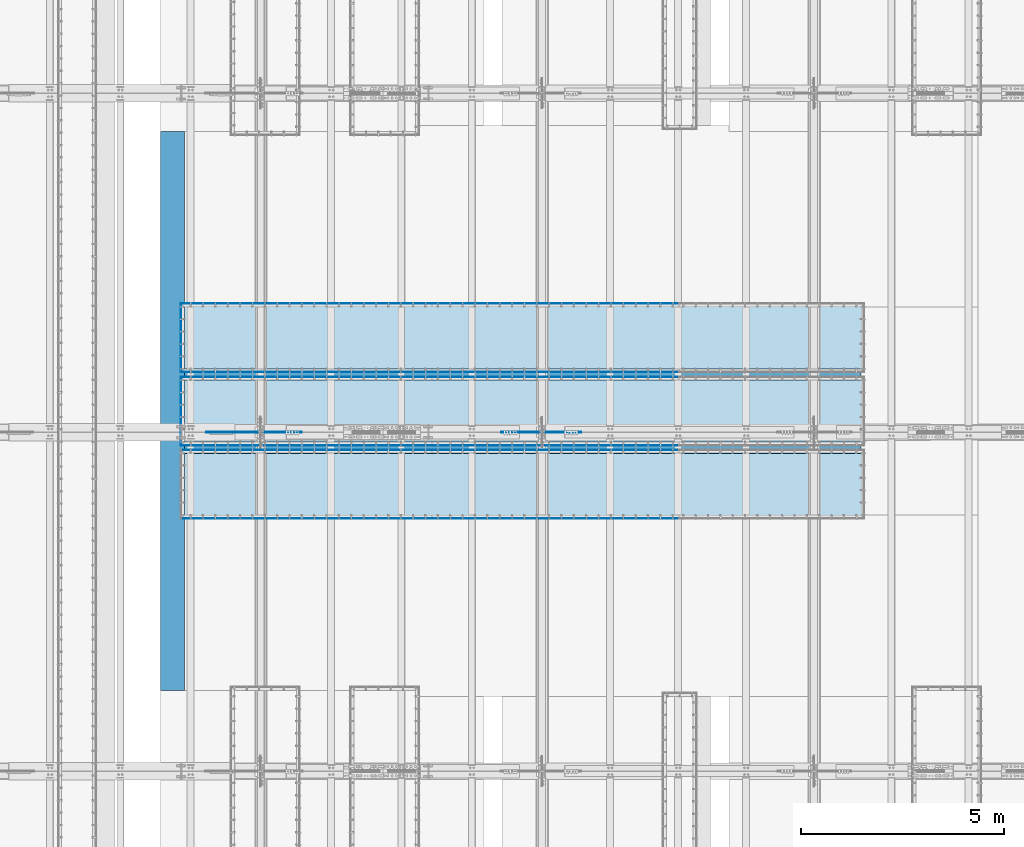
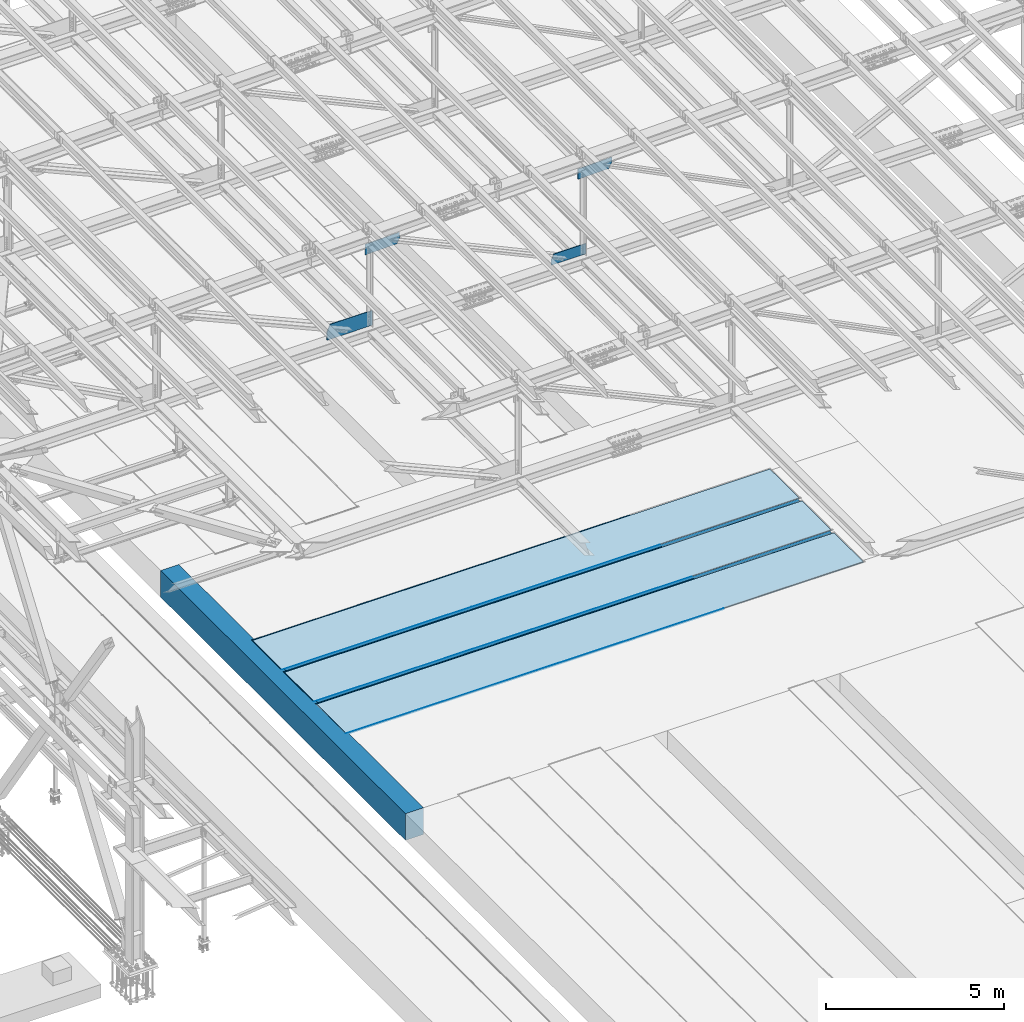
# One storey, part 2982 of 3843: 21 plates, 3 slabs, 24 elements without a shape of their own.
"""IFC2X3 building model written with IfcOpenShell, lengths in millimetres."""

from ifc_helpers import new_model, si_unit, frame, origin_with_axes, place, context, subcontext, project, spatial, faceted_brep, material, type_object, element, aggregate, save


model = new_model("IFC2X3")

# Units and contexts
model_context = context("Model", 3, precision=1e-05, world=origin_with_axes())
body_context = subcontext(model_context, "Body", "Model", "MODEL_VIEW")
ifc_project = project(units=[si_unit("LENGTHUNIT", "METRE", prefix="MILLI"), si_unit("AREAUNIT", "SQUARE_METRE"), si_unit("VOLUMEUNIT", "CUBIC_METRE"), si_unit("MASSUNIT", "GRAM", prefix="KILO"), si_unit("TIMEUNIT", "SECOND"), si_unit("PLANEANGLEUNIT", "RADIAN"), si_unit("SOLIDANGLEUNIT", "STERADIAN"), si_unit("THERMODYNAMICTEMPERATUREUNIT", "DEGREE_CELSIUS"), si_unit("LUMINOUSINTENSITYUNIT", "LUMEN")], contexts=[model_context])

# Site, building, storey
site_placement = place(None, origin_with_axes())
site = spatial("IfcSite", under=ifc_project, at=site_placement, CompositionType="ELEMENT")
building_placement = place(site_placement, origin_with_axes())
building = spatial("IfcBuilding", under=site, at=building_placement, Name="Undefined", CompositionType="ELEMENT")
storey_placement = place(building_placement, origin_with_axes())
storey = spatial("IfcBuildingStorey", under=building, at=storey_placement, Name="Undefined", CompositionType="ELEMENT", Elevation=0.0)

# Assembly, plate
assembly_1_placement = place(storey_placement, origin_with_axes())
assembly_1 = element("IfcElementAssembly", 1, at=assembly_1_placement, inside=storey, Name="EMBED_ANGLE", AssemblyPlace="NOTDEFINED", PredefinedType="RIGID_FRAME")
ifc_material_1 = material(Name="STEEL/A36")
plate_type_1 = type_object("IfcPlateType", PredefinedType="NOTDEFINED")
plate_1_placement = place(assembly_1_placement, frame((47028.862390625, 60391.294, 30480.0000003815), z_axis=(0.0, 1.0, 0.0), x_axis=(0.0, 0.0, -1.0)))
plate_1 = element("IfcPlate", 2, at=plate_1_placement, type_object=plate_type_1, material=ifc_material_1, Name="PLATE", context=body_context, shape_type="Brep", body=[
    faceted_brep([(7.27595761418343e-12, 6.3499999046162, 0.0), (20.6374996185295, 6.35000000000218, -7.27595761418343e-12), (25.399999618523, 1.58750000001601, 4.76249999998981), (25.3999996185303, -6.34999999999854, 12.7000000000044), (0.0, -6.34999999999854, 12.6999998092651), (25.3999996154307, 1.58750000001601, 1697.41850000675), (25.3999996185303, -6.34999999999854, 1689.48100001796), (3.78626282326877e-07, -6.34999999999854, 1689.48100001796), (3.81471181754023e-07, 6.34999999999854, 1702.181), (20.6374996154154, 6.34999999999854, 1702.18100000139)], [[[0, 1, 2, 3, 4]], [[3, 2, 5, 6]], [[4, 3, 6, 7]], [[0, 4, 7, 8]], [[1, 0, 8, 9]], [[2, 1, 9, 5]], [[8, 7, 6, 5, 9]]]),
])
aggregate(assembly_1, [plate_1])

assembly_2_placement = place(storey_placement, origin_with_axes())
assembly_2 = element("IfcElementAssembly", 3, at=assembly_2_placement, inside=storey, Name="EMBED_ANGLE", AssemblyPlace="NOTDEFINED", PredefinedType="RIGID_FRAME")
plate_2_placement = place(assembly_2_placement, frame((53207.4119781899, 60397.6439999965, 30480.0000025529), z_axis=(0.999999999868683, 0.0, 1.62059999202029e-05), x_axis=(1.62059999200984e-05, 0.0, -0.999999999868683)))
plate_2 = element("IfcPlate", 4, at=plate_2_placement, type_object=plate_type_1, material=ifc_material_1, Name="PLATE", context=body_context, shape_type="Brep", body=[
    faceted_brep([(25.4987902105895, -1.5874999999869, 6096.00000000218), (20.736291417099, -6.34999999999854, 6096.00009155487), (20.6375000381231, -6.35000000004948, 2.5465851649642e-11), (25.3999996185921, -1.5874999999869, 7.27595761418343e-11), (0.0, -6.3499999046162, 0.0), (0.0987892300327076, -6.34999999999854, 6096.00048828339), (0.0987892300327076, 6.34999999999854, 6096.00048828339), (7.27595761418343e-12, 6.3499999046162, 0.0), (25.4987888411197, 6.34999999999854, 6096.0000000022), (25.3999999999942, 6.34999999994034, 2.91038304567337e-11)], [[[0, 1, 2, 3]], [[4, 5, 6, 7]], [[8, 9, 7, 6]], [[9, 8, 0, 3]], [[4, 7, 9, 3, 2]], [[5, 4, 2, 1]], [[8, 6, 5, 1, 0]]]),
])
aggregate(assembly_2, [plate_2])

assembly_3_placement = place(storey_placement, origin_with_axes())
assembly_3 = element("IfcElementAssembly", 5, at=assembly_3_placement, inside=storey, Name="EMBED_ANGLE", AssemblyPlace="NOTDEFINED", PredefinedType="RIGID_FRAME")
plate_3_placement = place(assembly_3_placement, frame((47022.512390625, 60397.6439999965, 30480.0000025529), z_axis=(0.999999999868683, 0.0, 1.62059999202029e-05), x_axis=(1.62059999200984e-05, 0.0, -0.999999999868683)))
plate_3 = element("IfcPlate", 6, at=plate_3_placement, type_object=plate_type_1, material=ifc_material_1, Name="PLATE", context=body_context, shape_type="Brep", body=[
    faceted_brep([(25.5002296598104, 6.34999999999854, 6184.89958756838), (0.100230048672529, 6.34999999999854, 6184.90007584957), (0.100230048672529, -6.34999999999854, 6184.90007584957), (20.7377321294189, -6.34999999999854, 6184.89967912107), (25.5002309229349, -1.58749999997235, 6184.89958756837), (25.4002054231096, 6.34999999999854, 12.6995883069176), (0.000205811182240723, 6.34999999999854, 12.6999999392137), (0.0, -6.3499999046162, 0.0), (20.6375000381231, -6.35000000004948, 2.5465851649642e-11), (25.4000767920879, -1.58749999997235, 4.76208830797987)], [[[0, 1, 2, 3, 4]], [[1, 0, 5, 6]], [[2, 1, 6, 7]], [[3, 2, 7, 8]], [[4, 3, 8, 9]], [[0, 4, 9, 5]], [[8, 7, 6, 5, 9]]]),
])
aggregate(assembly_3, [plate_3])

assembly_4_placement = place(storey_placement, origin_with_axes())
assembly_4 = element("IfcElementAssembly", 7, at=assembly_4_placement, inside=storey, Name="EMBED_ANGLE", AssemblyPlace="NOTDEFINED", PredefinedType="RIGID_FRAME")
plate_4_placement = place(assembly_4_placement, frame((53207.4119781899, 62087.1249999965, 30480.0000025529), z_axis=(0.999999999868683, 0.0, 1.62059999202029e-05), x_axis=(1.62059999200984e-05, 0.0, -0.999999999868683)))
plate_4 = element("IfcPlate", 8, at=plate_4_placement, type_object=plate_type_1, material=ifc_material_1, Name="PLATE", context=body_context, shape_type="Brep", body=[
    faceted_brep([(25.4987943539782, 1.58750000000146, 6096.00000000211), (25.3999996185921, 1.58750000000146, 7.27595761418343e-11), (20.6374996185295, 6.35000000000218, -7.27595761418343e-12), (20.7362914171135, 6.34999999999854, 6096.00009155487), (0.0, -6.3499999046162, 0.0), (0.0987892300327076, -6.34999999999854, 6096.00048828339), (0.0987892300327076, 6.34999999999854, 6096.00048828339), (7.27595761418343e-12, 6.3499999046162, 0.0), (25.3999996185303, -6.34999999999491, 2.91038304567337e-11), (25.4987888411197, -6.34999999999854, 6096.0000000022)], [[[0, 1, 2, 3]], [[4, 5, 6, 7]], [[8, 9, 5, 4]], [[6, 5, 9, 0, 3]], [[7, 6, 3, 2]], [[8, 4, 7, 2, 1]], [[9, 8, 1, 0]]]),
])
aggregate(assembly_4, [plate_4])

assembly_5_placement = place(storey_placement, origin_with_axes())
assembly_5 = element("IfcElementAssembly", 9, at=assembly_5_placement, inside=storey, Name="EMBED_ANGLE", AssemblyPlace="NOTDEFINED", PredefinedType="RIGID_FRAME")
plate_5_placement = place(assembly_5_placement, frame((47022.5119781899, 62087.1249999965, 30480.0000025529), z_axis=(0.999999999868683, 0.0, 1.62059999202029e-05), x_axis=(1.62059999200984e-05, 0.0, -0.999999999868683)))
plate_5 = element("IfcPlate", 10, at=plate_5_placement, type_object=plate_type_1, material=ifc_material_1, Name="PLATE", context=body_context, shape_type="Brep", body=[
    faceted_brep([(0.100230055359134, 6.34999999999854, 6184.90048828463), (0.100230055359134, -6.34999999999854, 6184.90048828463), (25.500229666497, -6.34999999999854, 6184.90000000344), (25.5002350729919, 1.58750000003056, 6184.90000000335), (20.7377321361273, 6.34999999999854, 6184.90009155612), (25.4002054297998, -6.34999999999854, 12.7000008638424), (25.4000768019687, 1.58750000003056, 4.76250086484652), (20.6374996185295, 6.35000000000218, -7.27595761418343e-12), (7.27595761418343e-12, 6.3499999046162, 0.0), (0.000205817865207791, -6.34999999999854, 12.7004124961386)], [[[0, 1, 2, 3, 4]], [[3, 2, 5, 6]], [[4, 3, 6, 7]], [[0, 4, 7, 8]], [[1, 0, 8, 9]], [[2, 1, 9, 5]], [[8, 7, 6, 5, 9]]]),
])
aggregate(assembly_5, [plate_5])

assembly_6_placement = place(storey_placement, origin_with_axes())
assembly_6 = element("IfcElementAssembly", 11, at=assembly_6_placement, inside=storey, Name="EMBED_ANGLE", AssemblyPlace="NOTDEFINED", PredefinedType="RIGID_FRAME")
plate_6_placement = place(assembly_6_placement, frame((47028.862390625, 58587.894, 30480.0000003815), z_axis=(0.0, 1.0, 0.0), x_axis=(0.0, 0.0, -1.0)))
plate_6 = element("IfcPlate", 12, at=plate_6_placement, type_object=plate_type_1, material=ifc_material_1, Name="PLATE", context=body_context, shape_type="Brep", body=[
    faceted_brep([(7.27595761418343e-12, 6.3499999046162, 0.0), (20.6374996185295, 6.35000000000218, -7.27595761418343e-12), (25.399999618523, 1.58750000001601, 4.76249999998981), (25.3999996185303, -6.34999999999854, 12.7000000000044), (0.0, -6.34999999999854, 12.6999998092651), (25.3999996154307, 1.58750000001601, 1697.41850000675), (25.3999996185303, -6.34999999999854, 1689.48100001796), (3.78626282326877e-07, -6.34999999999854, 1689.48100001796), (3.81471181754023e-07, 6.34999999999854, 1702.181), (20.6374996154154, 6.34999999999854, 1702.18100000139)], [[[0, 1, 2, 3, 4]], [[3, 2, 5, 6]], [[4, 3, 6, 7]], [[0, 4, 7, 8]], [[1, 0, 8, 9]], [[2, 1, 9, 5]], [[8, 7, 6, 5, 9]]]),
])
aggregate(assembly_6, [plate_6])

assembly_7_placement = place(storey_placement, origin_with_axes())
assembly_7 = element("IfcElementAssembly", 13, at=assembly_7_placement, inside=storey, Name="EMBED_ANGLE", AssemblyPlace="NOTDEFINED", PredefinedType="RIGID_FRAME")
plate_7_placement = place(assembly_7_placement, frame((53207.4119781899, 58594.2439999965, 30480.0000025529), z_axis=(0.999999999868683, 0.0, 1.62059999202029e-05), x_axis=(1.62059999200984e-05, 0.0, -0.999999999868683)))
plate_7 = element("IfcPlate", 14, at=plate_7_placement, type_object=plate_type_1, material=ifc_material_1, Name="PLATE", context=body_context, shape_type="Brep", body=[
    faceted_brep([(25.4987902105895, -1.5874999999869, 6096.00000000218), (20.736291417099, -6.34999999999854, 6096.00009155487), (20.6375000381231, -6.35000000004948, 2.5465851649642e-11), (25.3999996185921, -1.5874999999869, 7.27595761418343e-11), (0.0, -6.3499999046162, 0.0), (0.0987892300327076, -6.34999999999854, 6096.00048828339), (0.0987892300327076, 6.34999999999854, 6096.00048828339), (7.27595761418343e-12, 6.3499999046162, 0.0), (25.4987888411197, 6.34999999999854, 6096.0000000022), (25.3999999999942, 6.34999999994034, 2.91038304567337e-11)], [[[0, 1, 2, 3]], [[4, 5, 6, 7]], [[8, 9, 7, 6]], [[9, 8, 0, 3]], [[4, 7, 9, 3, 2]], [[5, 4, 2, 1]], [[8, 6, 5, 1, 0]]]),
])
aggregate(assembly_7, [plate_7])

assembly_8_placement = place(storey_placement, origin_with_axes())
assembly_8 = element("IfcElementAssembly", 15, at=assembly_8_placement, inside=storey, Name="EMBED_ANGLE", AssemblyPlace="NOTDEFINED", PredefinedType="RIGID_FRAME")
plate_8_placement = place(assembly_8_placement, frame((47022.512390625, 58594.2439999965, 30480.0000025529), z_axis=(0.999999999868683, 0.0, 1.62059999202029e-05), x_axis=(1.62059999200984e-05, 0.0, -0.999999999868683)))
plate_8 = element("IfcPlate", 16, at=plate_8_placement, type_object=plate_type_1, material=ifc_material_1, Name="PLATE", context=body_context, shape_type="Brep", body=[
    faceted_brep([(25.5002296598104, 6.34999999999854, 6184.89958756838), (0.100230048672529, 6.34999999999854, 6184.90007584957), (0.100230048672529, -6.34999999999854, 6184.90007584957), (20.7377321294189, -6.34999999999854, 6184.89967912107), (25.5002309229349, -1.58749999997235, 6184.89958756837), (25.4002054231096, 6.34999999999854, 12.6995883069176), (0.000205811182240723, 6.34999999999854, 12.6999999392137), (0.0, -6.3499999046162, 0.0), (20.6375000381231, -6.35000000004948, 2.5465851649642e-11), (25.4000767920879, -1.58749999997235, 4.76208830797987)], [[[0, 1, 2, 3, 4]], [[1, 0, 5, 6]], [[2, 1, 6, 7]], [[3, 2, 7, 8]], [[4, 3, 8, 9]], [[0, 4, 9, 5]], [[8, 7, 6, 5, 9]]]),
])
aggregate(assembly_8, [plate_8])

assembly_9_placement = place(storey_placement, origin_with_axes())
assembly_9 = element("IfcElementAssembly", 17, at=assembly_9_placement, inside=storey, Name="EMBED_ANGLE", AssemblyPlace="NOTDEFINED", PredefinedType="RIGID_FRAME")
plate_9_placement = place(assembly_9_placement, frame((53207.4119781899, 60283.7249999965, 30480.0000025529), z_axis=(0.999999999868683, 0.0, 1.62059999202029e-05), x_axis=(1.62059999200984e-05, 0.0, -0.999999999868683)))
plate_9 = element("IfcPlate", 18, at=plate_9_placement, type_object=plate_type_1, material=ifc_material_1, Name="PLATE", context=body_context, shape_type="Brep", body=[
    faceted_brep([(25.4987943539782, 1.58750000000146, 6096.00000000211), (25.3999996185921, 1.58750000000146, 7.27595761418343e-11), (20.6374996185295, 6.35000000000218, -7.27595761418343e-12), (20.7362914171135, 6.34999999999854, 6096.00009155487), (0.0, -6.3499999046162, 0.0), (0.0987892300327076, -6.34999999999854, 6096.00048828339), (0.0987892300327076, 6.34999999999854, 6096.00048828339), (7.27595761418343e-12, 6.3499999046162, 0.0), (25.3999996185303, -6.34999999999491, 2.91038304567337e-11), (25.4987888411197, -6.34999999999854, 6096.0000000022)], [[[0, 1, 2, 3]], [[4, 5, 6, 7]], [[8, 9, 5, 4]], [[6, 5, 9, 0, 3]], [[7, 6, 3, 2]], [[8, 4, 7, 2, 1]], [[9, 8, 1, 0]]]),
])
aggregate(assembly_9, [plate_9])

assembly_10_placement = place(storey_placement, origin_with_axes())
assembly_10 = element("IfcElementAssembly", 19, at=assembly_10_placement, inside=storey, Name="EMBED_ANGLE", AssemblyPlace="NOTDEFINED", PredefinedType="RIGID_FRAME")
plate_10_placement = place(assembly_10_placement, frame((47022.5119781899, 60283.7249999965, 30480.0000025529), z_axis=(0.999999999868683, 0.0, 1.62059999202029e-05), x_axis=(1.62059999200984e-05, 0.0, -0.999999999868683)))
plate_10 = element("IfcPlate", 20, at=plate_10_placement, type_object=plate_type_1, material=ifc_material_1, Name="PLATE", context=body_context, shape_type="Brep", body=[
    faceted_brep([(0.100230055359134, 6.34999999999854, 6184.90048828463), (0.100230055359134, -6.34999999999854, 6184.90048828463), (25.500229666497, -6.34999999999854, 6184.90000000344), (25.5002350729919, 1.58750000003056, 6184.90000000335), (20.7377321361273, 6.34999999999854, 6184.90009155612), (25.4002054297998, -6.34999999999854, 12.7000008638424), (25.4000768019687, 1.58750000003056, 4.76250086484652), (20.6374996185295, 6.35000000000218, -7.27595761418343e-12), (7.27595761418343e-12, 6.3499999046162, 0.0), (0.000205817865207791, -6.34999999999854, 12.7004124961386)], [[[0, 1, 2, 3, 4]], [[3, 2, 5, 6]], [[4, 3, 6, 7]], [[0, 4, 7, 8]], [[1, 0, 8, 9]], [[2, 1, 9, 5]], [[8, 7, 6, 5, 9]]]),
])
aggregate(assembly_10, [plate_10])

assembly_11_placement = place(storey_placement, origin_with_axes())
assembly_11 = element("IfcElementAssembly", 21, at=assembly_11_placement, inside=storey, Name="EMBED_ANGLE", AssemblyPlace="NOTDEFINED", PredefinedType="RIGID_FRAME")
plate_11_placement = place(assembly_11_placement, frame((53207.4115665688, 56791.225, 30480.0000025529), z_axis=(0.999999999868683, 0.0, 1.62059999202029e-05), x_axis=(1.62059999200984e-05, 0.0, -0.999999999868683)))
plate_11 = element("IfcPlate", 22, at=plate_11_placement, type_object=plate_type_1, material=ifc_material_1, Name="PLATE", context=body_context, shape_type="Brep", body=[
    faceted_brep([(25.4987902105895, -1.5874999999869, 6096.00000000218), (20.736291417099, -6.34999999999854, 6096.00009155487), (20.6375000381231, -6.35000000004948, 2.5465851649642e-11), (25.3999996185921, -1.5874999999869, 7.27595761418343e-11), (0.0, -6.3499999046162, 0.0), (0.0987892300327076, -6.34999999999854, 6096.00048828339), (0.0987892300327076, 6.34999999999854, 6096.00048828339), (7.27595761418343e-12, 6.3499999046162, 0.0), (25.4987888411197, 6.34999999999854, 6096.0000000022), (25.3999999999942, 6.34999999994034, 2.91038304567337e-11)], [[[0, 1, 2, 3]], [[4, 5, 6, 7]], [[8, 9, 7, 6]], [[9, 8, 0, 3]], [[4, 7, 9, 3, 2]], [[5, 4, 2, 1]], [[8, 6, 5, 1, 0]]]),
])
aggregate(assembly_11, [plate_11])

assembly_12_placement = place(storey_placement, origin_with_axes())
assembly_12 = element("IfcElementAssembly", 23, at=assembly_12_placement, inside=storey, Name="EMBED_ANGLE", AssemblyPlace="NOTDEFINED", PredefinedType="RIGID_FRAME")
plate_12_placement = place(assembly_12_placement, frame((47022.5119790039, 56791.225, 30480.0000025529), z_axis=(0.999999999868683, 0.0, 1.62059999202029e-05), x_axis=(1.62059999200984e-05, 0.0, -0.999999999868683)))
plate_12 = element("IfcPlate", 24, at=plate_12_placement, type_object=plate_type_1, material=ifc_material_1, Name="PLATE", context=body_context, shape_type="Brep", body=[
    faceted_brep([(25.5002296598104, 6.34999999999854, 6184.89958756838), (0.100230048672529, 6.34999999999854, 6184.90007584957), (0.100230048672529, -6.34999999999854, 6184.90007584957), (20.7377321294189, -6.34999999999854, 6184.89967912107), (25.5002309229349, -1.58749999997235, 6184.89958756837), (25.4002054231096, 6.34999999999854, 12.6995883069176), (0.000205811182240723, 6.34999999999854, 12.6999999392137), (0.0, -6.3499999046162, 0.0), (20.6375000381231, -6.35000000004948, 2.5465851649642e-11), (25.4000767920879, -1.58749999997235, 4.76208830797987)], [[[0, 1, 2, 3, 4]], [[1, 0, 5, 6]], [[2, 1, 6, 7]], [[3, 2, 7, 8]], [[4, 3, 8, 9]], [[0, 4, 9, 5]], [[8, 7, 6, 5, 9]]]),
])
aggregate(assembly_12, [plate_12])

assembly_13_placement = place(storey_placement, origin_with_axes())
assembly_13 = element("IfcElementAssembly", 25, at=assembly_13_placement, inside=storey, Name="EMBED_ANGLE", AssemblyPlace="NOTDEFINED", PredefinedType="RIGID_FRAME")
plate_13_placement = place(assembly_13_placement, frame((53207.4115665688, 58480.706, 30480.0000025529), z_axis=(0.999999999868683, 0.0, 1.62059999202029e-05), x_axis=(1.62059999200984e-05, 0.0, -0.999999999868683)))
plate_13 = element("IfcPlate", 26, at=plate_13_placement, type_object=plate_type_1, material=ifc_material_1, Name="PLATE", context=body_context, shape_type="Brep", body=[
    faceted_brep([(25.4987943539782, 1.58750000000146, 6096.00000000211), (25.3999996185921, 1.58750000000146, 7.27595761418343e-11), (20.6374996185295, 6.35000000000218, -7.27595761418343e-12), (20.7362914171135, 6.34999999999854, 6096.00009155487), (0.0, -6.3499999046162, 0.0), (0.0987892300327076, -6.34999999999854, 6096.00048828339), (0.0987892300327076, 6.34999999999854, 6096.00048828339), (7.27595761418343e-12, 6.3499999046162, 0.0), (25.3999996185303, -6.34999999999491, 2.91038304567337e-11), (25.4987888411197, -6.34999999999854, 6096.0000000022)], [[[0, 1, 2, 3]], [[4, 5, 6, 7]], [[8, 9, 5, 4]], [[6, 5, 9, 0, 3]], [[7, 6, 3, 2]], [[8, 4, 7, 2, 1]], [[9, 8, 1, 0]]]),
])
aggregate(assembly_13, [plate_13])

assembly_14_placement = place(storey_placement, origin_with_axes())
assembly_14 = element("IfcElementAssembly", 27, at=assembly_14_placement, inside=storey, Name="EMBED_ANGLE", AssemblyPlace="NOTDEFINED", PredefinedType="RIGID_FRAME")
plate_14_placement = place(assembly_14_placement, frame((47022.5115665688, 58480.706, 30480.0000025529), z_axis=(0.999999999868683, 0.0, 1.62059999202029e-05), x_axis=(1.62059999200984e-05, 0.0, -0.999999999868683)))
plate_14 = element("IfcPlate", 28, at=plate_14_placement, type_object=plate_type_1, material=ifc_material_1, Name="PLATE", context=body_context, shape_type="Brep", body=[
    faceted_brep([(0.100230055359134, 6.34999999999854, 6184.90048828463), (0.100230055359134, -6.34999999999854, 6184.90048828463), (25.500229666497, -6.34999999999854, 6184.90000000344), (25.5002350729919, 1.58750000003056, 6184.90000000335), (20.7377321361273, 6.34999999999854, 6184.90009155612), (25.4002054297998, -6.34999999999854, 12.7000008638424), (25.4000768019687, 1.58750000003056, 4.76250086484652), (20.6374996185295, 6.35000000000218, -7.27595761418343e-12), (7.27595761418343e-12, 6.3499999046162, 0.0), (0.000205817865207791, -6.34999999999854, 12.7004124961386)], [[[0, 1, 2, 3, 4]], [[3, 2, 5, 6]], [[4, 3, 6, 7]], [[0, 4, 7, 8]], [[1, 0, 8, 9]], [[2, 1, 9, 5]], [[8, 7, 6, 5, 9]]]),
])
aggregate(assembly_14, [plate_14])

assembly_15_placement = place(storey_placement, origin_with_axes())
assembly_15 = element("IfcElementAssembly", 29, at=assembly_15_placement, inside=storey, Name="TRENCH COVER", AssemblyPlace="NOTDEFINED", PredefinedType="RIGID_FRAME")
ifc_material_2 = material(Name="STEEL/Steel_Undefined")
plate_type_2 = type_object("IfcPlateType", PredefinedType="NOTDEFINED")
plate_15_placement = place(assembly_15_placement, frame((47047.9125641289, 62067.9849437687, 30467.3), z_axis=(1.0, 0.0, 0.0), x_axis=(0.0, -1.0, 0.0)))
plate_15 = element("IfcPlate", 30, at=plate_15_placement, type_object=plate_type_2, material=ifc_material_2, Name="TRENCH COVER", context=body_context, shape_type="Brep", body=[
    faceted_brep([(0.0, -12.6999999999971, 0.0), (0.00240426734671928, -12.7000000000007, 16802.0996099652), (0.00240426734671928, 12.7000000000007, 16802.0996099652), (0.0, 12.6999999999971, 0.0), (1651.38360647034, -12.7000000000007, 16802.0993728866), (1651.38360647034, 12.7000000000007, 16802.0993728866), (1651.47125841813, -12.7000000000007, -9.45874489843845e-11), (1651.47125841813, 12.7000000000007, -9.45874489843845e-11)], [[[0, 1, 2, 3]], [[1, 4, 5, 2]], [[4, 6, 7, 5]], [[6, 0, 3, 7]], [[5, 7, 3, 2]], [[6, 4, 1, 0]]]),
])
aggregate(assembly_15, [plate_15])

assembly_16_placement = place(storey_placement, origin_with_axes())
assembly_16 = element("IfcElementAssembly", 31, at=assembly_16_placement, inside=storey, Name="TRENCH COVER", AssemblyPlace="NOTDEFINED", PredefinedType="RIGID_FRAME")
plate_16_placement = place(assembly_16_placement, frame((47047.9125641289, 60264.5849437687, 30467.3), z_axis=(1.0, 0.0, 0.0), x_axis=(0.0, -1.0, 0.0)))
plate_16 = element("IfcPlate", 32, at=plate_16_placement, type_object=plate_type_2, material=ifc_material_2, Name="TRENCH COVER", context=body_context, shape_type="Brep", body=[
    faceted_brep([(0.0, -12.6999999999971, 0.0), (0.00240426734671928, -12.7000000000007, 16802.0996099652), (0.00240426734671928, 12.7000000000007, 16802.0996099652), (0.0, 12.6999999999971, 0.0), (1651.38360647034, -12.7000000000007, 16802.0993728866), (1651.38360647034, 12.7000000000007, 16802.0993728866), (1651.47125841813, -12.7000000000007, -9.45874489843845e-11), (1651.47125841813, 12.7000000000007, -9.45874489843845e-11)], [[[0, 1, 2, 3]], [[1, 4, 5, 2]], [[4, 6, 7, 5]], [[6, 0, 3, 7]], [[5, 7, 3, 2]], [[6, 4, 1, 0]]]),
])
aggregate(assembly_16, [plate_16])

assembly_17_placement = place(storey_placement, origin_with_axes())
assembly_17 = element("IfcElementAssembly", 33, at=assembly_17_placement, inside=storey, Name="TRENCH COVER", AssemblyPlace="NOTDEFINED", PredefinedType="RIGID_FRAME")
plate_17_placement = place(assembly_17_placement, frame((47047.9117408839, 58461.655999924, 30467.3), z_axis=(1.0, 0.0, 0.0), x_axis=(0.0, -1.0, 0.0)))
plate_17 = element("IfcPlate", 34, at=plate_17_placement, type_object=plate_type_2, material=ifc_material_2, Name="TRENCH COVER", context=body_context, shape_type="Brep", body=[
    faceted_brep([(0.0, -12.6999999999971, 0.0), (0.00240426734671928, -12.7000000000007, 16802.0996099652), (0.00240426734671928, 12.7000000000007, 16802.0996099652), (0.0, 12.6999999999971, 0.0), (1651.38360647034, -12.7000000000007, 16802.0993728866), (1651.38360647034, 12.7000000000007, 16802.0993728866), (1651.47125841813, -12.7000000000007, -9.45874489843845e-11), (1651.47125841813, 12.7000000000007, -9.45874489843845e-11)], [[[0, 1, 2, 3]], [[1, 4, 5, 2]], [[4, 6, 7, 5]], [[6, 0, 3, 7]], [[5, 7, 3, 2]], [[6, 4, 1, 0]]]),
])
aggregate(assembly_17, [plate_17])

assembly_18_placement = place(storey_placement, origin_with_axes())
assembly_18 = element("IfcElementAssembly", 35, at=assembly_18_placement, inside=storey, Name="BEAM", AssemblyPlace="NOTDEFINED", PredefinedType="RIGID_FRAME")
ifc_material_3 = material(Name="STEEL/A572-50")
plate_type_3 = type_object("IfcPlateType", PredefinedType="NOTDEFINED")
plate_18_placement = place(assembly_18_placement, frame((56893.9555263649, 58915.3, 45541.1050503529), z_axis=(0.0236924809946432, 0.0, -0.999719293774167), x_axis=(-0.999719293774167, 0.0, -0.0236924809946454)))
plate_18 = element("IfcPlate", 36, at=plate_18_placement, type_object=plate_type_3, material=ifc_material_3, Name="PLATE", context=body_context, shape_type="Brep", body=[
    faceted_brep([(0.0, -9.52500000000146, 0.0), (5.82076609134674e-11, -9.52500000000146, 155.103184727617), (5.82076609134674e-11, 9.52500000000146, 155.103184727617), (0.0, 9.52500000000146, 0.0), (107.503775064462, -9.52500000000146, 356.847821968309), (107.503775064462, 9.52500000000146, 356.847821968309), (1111.62217591173, -9.52500000000146, 356.847821967873), (1111.62217591173, 9.52500000000146, 356.847821967873), (1103.1651917032, -9.52500000000146, -4.65661287307739e-10), (1103.1651917032, 9.52500000000146, -4.65661287307739e-10)], [[[0, 1, 2, 3]], [[1, 4, 5, 2]], [[4, 6, 7, 5]], [[6, 8, 9, 7]], [[8, 0, 3, 9]], [[5, 7, 9, 3, 2]], [[8, 6, 4, 1, 0]]]),
])
aggregate(assembly_18, [plate_18])

assembly_19_placement = place(storey_placement, origin_with_axes())
assembly_19 = element("IfcElementAssembly", 37, at=assembly_19_placement, inside=storey, Name="BEAM", AssemblyPlace="NOTDEFINED", PredefinedType="RIGID_FRAME")
plate_type_4 = type_object("IfcPlateType", PredefinedType="NOTDEFINED")
plate_19_placement = place(assembly_19_placement, frame((50000.2611835769, 58915.3, 45374.9359234629), z_axis=(0.0250134929908746, 0.0, -0.999687113635259), x_axis=(-0.999687113635259, 0.0, -0.0250134929908735)))
plate_19 = element("IfcPlate", 38, at=plate_19_placement, type_object=plate_type_4, material=ifc_material_3, Name="PLATE", context=body_context, shape_type="Brep", body=[
    faceted_brep([(0.0, -9.52500000000146, 0.0), (4.29281499236822e-10, -9.52500000000146, 176.57870524413), (4.29281499236822e-10, 9.52500000000146, 176.57870524413), (0.0, 9.52500000000146, 0.0), (92.8830272497362, -9.52500000000146, 364.418919875716), (92.8830272497362, 9.52500000000146, 364.418919875716), (1127.40163478404, -9.52500000000146, 364.418919873213), (1127.40163478404, 9.52500000000146, 364.418919873213), (1118.67354424719, -9.52500000000146, -2.71393219009042e-09), (1118.67354424719, 9.52500000000146, -2.71393219009042e-09)], [[[0, 1, 2, 3]], [[1, 4, 5, 2]], [[4, 6, 7, 5]], [[6, 8, 9, 7]], [[8, 0, 3, 9]], [[5, 7, 9, 3, 2]], [[8, 6, 4, 1, 0]]]),
])
aggregate(assembly_19, [plate_19])

assembly_20_placement = place(storey_placement, origin_with_axes())
assembly_20 = element("IfcElementAssembly", 39, at=assembly_20_placement, inside=storey, Name="BEAM", AssemblyPlace="NOTDEFINED", PredefinedType="RIGID_FRAME")
plate_type_5 = type_object("IfcPlateType", PredefinedType="NOTDEFINED")
plate_20_placement = place(assembly_20_placement, frame((49112.8994901838, 58915.3, 42493.5147894441), z_axis=(-0.00394075500076725, 0.0, 0.999992235194866), x_axis=(-0.999992235194866, 0.0, -0.00394075500077012)))
plate_20 = element("IfcPlate", 40, at=plate_20_placement, type_object=plate_type_5, material=ifc_material_3, Name="PLATE", context=body_context, shape_type="Brep", body=[
    faceted_brep([(0.0, -9.52500000000146, 0.0), (-7.42147676646709e-10, -9.52500000000146, 507.802893931039), (-7.42147676646709e-10, 9.52500000000146, 507.802893931039), (0.0, 9.52500000000146, 0.0), (1368.3283398159, -9.52500000000146, 513.194271623805), (1368.3283398159, 9.52500000000146, 513.194271623805), (1471.77964241167, -9.52500000000146, 281.216190483261), (1471.77964241167, 9.52500000000146, 281.216190483261), (1471.77964241208, -9.52500000000146, 2.08092387765646e-09), (1471.77964241208, 9.52500000000146, 2.08092387765646e-09)], [[[0, 1, 2, 3]], [[1, 4, 5, 2]], [[4, 6, 7, 5]], [[6, 8, 9, 7]], [[8, 0, 3, 9]], [[5, 7, 9, 3, 2]], [[8, 6, 4, 1, 0]]]),
])
aggregate(assembly_20, [plate_20])

assembly_21_placement = place(storey_placement, origin_with_axes())
assembly_21 = element("IfcElementAssembly", 41, at=assembly_21_placement, inside=storey, Name="BEAM", AssemblyPlace="NOTDEFINED", PredefinedType="RIGID_FRAME")
plate_type_6 = type_object("IfcPlateType", PredefinedType="NOTDEFINED")
plate_21_placement = place(assembly_21_placement, frame((56046.0271853446, 58915.3, 42515.4801968735), z_axis=(-0.00261554900116607, 0.0, 0.999996579445861), x_axis=(-0.999996579445861, 0.0, -0.00261554900116633)))
plate_21 = element("IfcPlate", 42, at=plate_21_placement, type_object=plate_type_6, material=ifc_material_3, Name="PLATE", context=body_context, shape_type="Brep", body=[
    faceted_brep([(0.0, -9.52500000000146, 0.0), (-1.24418875202537e-09, -9.52500000000146, 356.068174505344), (-1.24418875202537e-09, 9.52500000000146, 356.068174505344), (0.0, 9.52500000000146, 0.0), (1037.6911231257, -9.52500000000146, 358.782315934477), (1037.6911231257, 9.52500000000146, 358.782315934477), (1123.65704050023, -9.52500000000146, 174.662513848467), (1123.65704050023, 9.52500000000146, 174.662513848467), (1123.65704050084, -9.52500000000146, 3.89991328120232e-09), (1123.65704050084, 9.52500000000146, 3.89991328120232e-09)], [[[0, 1, 2, 3]], [[1, 4, 5, 2]], [[4, 6, 7, 5]], [[6, 8, 9, 7]], [[8, 0, 3, 9]], [[5, 7, 9, 3, 2]], [[8, 6, 4, 1, 0]]]),
])
aggregate(assembly_21, [plate_21])

# Assembly, slab
assembly_22_placement = place(storey_placement, origin_with_axes())
assembly_22 = element("IfcElementAssembly", 43, at=assembly_22_placement, inside=storey, Name="SLAB", AssemblyPlace="NOTDEFINED", PredefinedType="REINFORCEMENT_UNIT")
ifc_material_4 = material(Name="CONCRETE/3000")
slab_type_1 = type_object("IfcSlabType", PredefinedType="NOTDEFINED")
slab_1_placement = place(assembly_22_placement, frame((63786.512, 60480.194, 30022.8), z_axis=(0.0, -1.0, 0.0), x_axis=(-1.0, 0.0, 0.0)))
slab_1 = element("IfcSlab", 44, at=slab_1_placement, type_object=slab_type_1, material=ifc_material_4, Name="SLAB", PredefinedType="FLOOR", context=body_context, shape_type="Brep", body=[
    faceted_brep([(16675.099609375, -431.800002968022, 76.1999960956673), (0.0, -432.070239610497, 76.2902584031763), (0.0, -432.070236711192, 0.0), (16675.099609375, -431.800000068728, 0.0), (16675.099609375, -457.200002589943, 76.1999961102119), (0.0, -457.200000000001, 76.2902584175681), (16675.099609375, 457.200000000001, 279.399993896484), (16675.099609375, 457.200000000001, 0.0), (0.0, 457.200000000001, 0.0), (0.0, 457.200000000001, 279.399993896484), (0.0, -432.070236703385, 279.399993896484), (16675.099609375, -431.800000060917, 279.39999391554), (0.0, -432.070239664441, 202.819000020092), (16675.099609375, -431.800003021974, 202.819000020092), (16675.099609375, -457.200000000001, 202.819000011863), (0.0, -457.200000000001, 202.819000020871)], [[[0, 1, 2, 3]], [[4, 5, 1, 0]], [[6, 7, 8, 9]], [[6, 9, 10, 11]], [[11, 10, 12, 13]], [[14, 13, 12, 15]], [[3, 7, 6, 11, 13, 14, 4, 0]], [[8, 7, 3, 2]], [[15, 12, 10, 9, 8, 2, 1, 5]], [[14, 15, 5, 4]]]),
])
aggregate(assembly_22, [slab_1])

assembly_23_placement = place(storey_placement, origin_with_axes())
assembly_23 = element("IfcElementAssembly", 45, at=assembly_23_placement, inside=storey, Name="SLAB", AssemblyPlace="NOTDEFINED", PredefinedType="REINFORCEMENT_UNIT")
slab_2_placement = place(assembly_23_placement, frame((63786.512, 58676.794, 30022.8), z_axis=(0.0, -1.0, 0.0), x_axis=(-1.0, 0.0, 0.0)))
slab_2 = element("IfcSlab", 46, at=slab_2_placement, type_object=slab_type_1, material=ifc_material_4, Name="SLAB", PredefinedType="FLOOR", context=body_context, shape_type="Brep", body=[
    faceted_brep([(16675.099609375, -457.200000963832, 202.437997392066), (16675.099609375, -431.800002974702, 202.437997400884), (0.0, -432.070239617187, 202.259457094144), (0.0, -457.200000000001, 202.259457094362), (16675.099609375, -431.800000060917, 279.39999391554), (0.0, -432.070236703385, 279.399993896484), (16675.099609375, -457.200002589943, 76.1999961102119), (0.0, -457.200000000001, 76.2045997006207), (0.0, -431.799999991825, 76.2045996881425), (16675.099609375, -431.800002968022, 76.1999960956673), (0.0, -431.800000000287, 0.0), (16675.099609375, -431.800000068728, 0.0), (0.0, 457.200000000001, 0.0), (16675.099609375, 457.200000000001, 0.0), (16675.099609375, 457.200000000001, 279.399993896484), (0.0, 457.200000000001, 279.399993896484)], [[[0, 1, 2, 3]], [[4, 5, 2, 1]], [[6, 7, 8, 9]], [[9, 8, 10, 11]], [[12, 13, 11, 10]], [[14, 13, 12, 15]], [[0, 6, 9, 11, 13, 14, 4, 1]], [[7, 6, 0, 3]], [[15, 12, 10, 8, 7, 3, 2, 5]], [[14, 15, 5, 4]]]),
])
aggregate(assembly_23, [slab_2])

assembly_24_placement = place(storey_placement, origin_with_axes())
assembly_24 = element("IfcElementAssembly", 47, at=assembly_24_placement, inside=storey, Name="SLAB", AssemblyPlace="NOTDEFINED", PredefinedType="REINFORCEMENT_UNIT")
slab_type_2 = type_object("IfcSlabType", PredefinedType="NOTDEFINED")
slab_3_placement = place(assembly_24_placement, frame((46519.846, 66325.877734375, 30022.8), z_axis=(1.0, 0.0, 0.0), x_axis=(0.0, -1.0, 0.0)))
slab_3 = element("IfcSlab", 48, at=slab_3_placement, type_object=slab_type_2, material=ifc_material_4, Name="SLAB", PredefinedType="FLOOR", context=body_context, shape_type="Brep", body=[
    faceted_brep([(4245.01247588127, -431.800008367027, 591.565740075959), (4245.01247590788, -431.800008367027, 515.365740075933), (5921.88373432553, -431.800003334181, 515.365978189962), (5921.8837342989, -431.800003334181, 591.565978189967), (4245.01247595741, -457.200000000001, 591.565979003906), (4245.01247598403, -457.200000000001, 515.365740075933), (5921.88373440167, -457.200000000001, 515.365978189962), (5921.88373437504, -457.200000000001, 591.565978189967), (13773.27734375, -457.200000000001, 0.0), (0.0, -457.200000000001, 0.0), (0.0, 457.200000000001, 0.0), (13773.27734375, 457.200000000001, 0.0), (0.0, -457.200000000001, 591.565979003906), (0.0, 457.200000000001, 591.565979003906), (13773.27734375, 457.200000000001, 591.565979003906), (13773.27734375, -457.200000000001, 591.565979003906), (9528.39299286866, -457.200000000001, 515.365979003931), (9528.39299279252, -431.800000781244, 515.365979003931), (7851.52173437487, -431.80000581409, 515.365740889902), (7851.52173445102, -457.200000000001, 515.365740889902), (9528.39299284203, -457.200000000001, 591.565979003935), (9528.39299276589, -431.800000781244, 591.565979003935), (7851.52173434826, -431.80000581409, 591.565740889928), (7851.5217344244, -457.200000000001, 591.565979003906), (7725.28373440166, -457.200000000001, 515.366369617535), (7725.28373432552, -431.800003334163, 515.366369617535), (6048.41247590787, -431.800008367009, 515.366131503506), (6048.41247598401, -457.200000000001, 515.366131503506), (7725.28373437503, -457.200000000001, 591.56636961754), (7725.28373429889, -431.800003334163, 591.56636961754), (6048.41247588125, -431.800008367009, 591.566131503532), (6048.4124759574, -457.200000000001, 591.565979003906)], [[[0, 1, 2, 3]], [[4, 5, 1, 0]], [[6, 2, 1, 5]], [[7, 3, 2, 6]], [[8, 9, 10, 11]], [[9, 12, 13, 10]], [[14, 11, 10, 13]], [[15, 8, 11, 14]], [[16, 17, 18, 19]], [[20, 21, 17, 16]], [[22, 18, 17, 21]], [[23, 19, 18, 22]], [[24, 25, 26, 27]], [[28, 29, 25, 24]], [[30, 26, 25, 29]], [[31, 27, 26, 30]], [[5, 4, 12, 9, 8, 15, 20, 16, 19, 23, 28, 24, 27, 31, 7, 6]], [[31, 30, 29, 28, 23, 22, 21, 20, 15, 14, 13, 12, 4, 0, 3, 7]]]),
])
aggregate(assembly_24, [slab_3])

save(model, "model.ifc")
